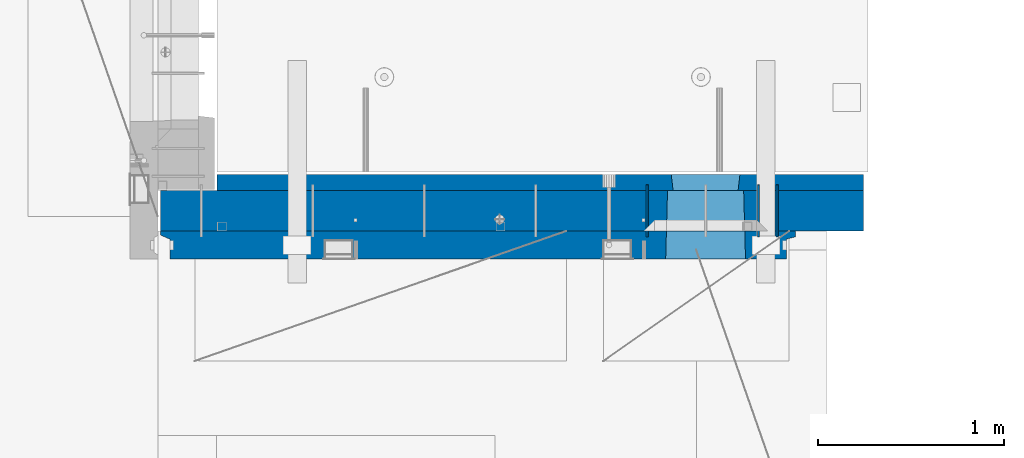
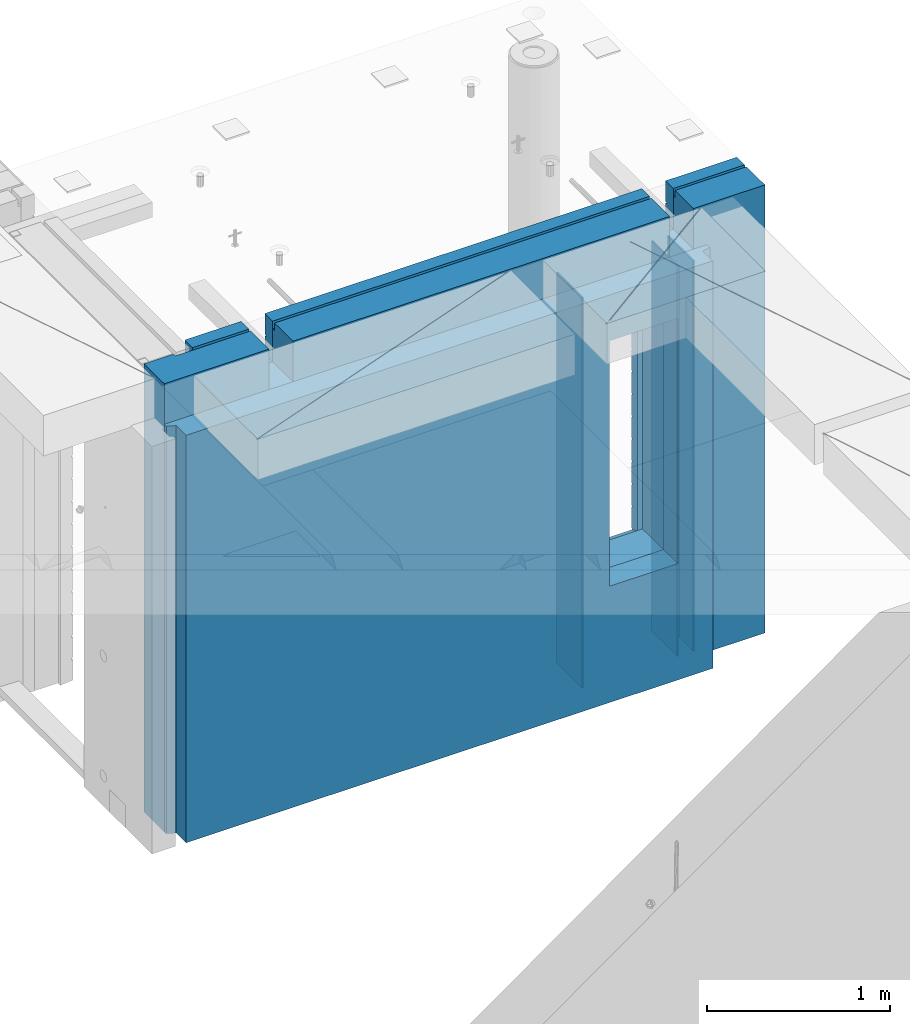
# One storey, part 207 of 309: 6 walls, 1 element without a shape of its own.
"""IFC2X3 building model written with IfcOpenShell, lengths in millimetres."""

from ifc_helpers import new_model, si_unit, frame, origin_with_axes, place, context, subcontext, project, spatial, faceted_brep, material, type_object, element, aggregate, save


model = new_model("IFC2X3")

# Units and contexts
model_context = context("Model", 3, precision=1e-05, world=origin_with_axes())
body_context = subcontext(model_context, "Body", "Model", "MODEL_VIEW")
ifc_project = project(units=[si_unit("LENGTHUNIT", "METRE", prefix="MILLI"), si_unit("AREAUNIT", "SQUARE_METRE"), si_unit("VOLUMEUNIT", "CUBIC_METRE"), si_unit("MASSUNIT", "GRAM", prefix="KILO"), si_unit("TIMEUNIT", "SECOND"), si_unit("PLANEANGLEUNIT", "RADIAN"), si_unit("SOLIDANGLEUNIT", "STERADIAN"), si_unit("THERMODYNAMICTEMPERATUREUNIT", "DEGREE_CELSIUS"), si_unit("LUMINOUSINTENSITYUNIT", "LUMEN")], contexts=[model_context])

# Site, building, storey
site_placement = place(None, origin_with_axes())
site = spatial("IfcSite", under=ifc_project, at=site_placement, CompositionType="ELEMENT")
building_placement = place(site_placement, origin_with_axes())
building = spatial("IfcBuilding", under=site, at=building_placement, CompositionType="ELEMENT")
storey_placement = place(building_placement, origin_with_axes())
storey = spatial("IfcBuildingStorey", under=building, at=storey_placement, Name="7", CompositionType="ELEMENT", Elevation=0.0)

# Assembly, walls
assembly_placement = place(storey_placement, origin_with_axes())
assembly = element("IfcElementAssembly", 1, at=assembly_placement, inside=storey, AssemblyPlace="NOTDEFINED", PredefinedType="REINFORCEMENT_UNIT")
ifc_material_1 = material(Name="Undefined")
wall_type_1 = type_object("IfcWallType", PredefinedType="NOTDEFINED")
wall_1_placement = place(assembly_placement, frame((34695.0, 20549.9951872276, 101115.0), z_axis=(0.0, 0.0, 1.0), x_axis=(0.0, 1.0, 0.0)))
wall_1 = element("IfcWall", 2, at=wall_1_placement, type_object=wall_type_1, material=ifc_material_1, Name="(PD)", context=body_context, shape_type="Brep", body=[
    faceted_brep([(0.0, 5.0, -1300.0), (0.0, 5.0, 1300.0), (280.0, 5.0, 1300.0), (280.0, 5.0, -1300.0), (0.0, -5.0, 1300.0), (280.0, -5.0, 1300.0), (0.0, -5.0, -1300.0), (280.0, -5.0, -1300.0)], [[[0, 1, 2, 3]], [[1, 4, 5, 2]], [[4, 6, 7, 5]], [[6, 0, 3, 7]], [[5, 7, 3, 2]], [[6, 4, 1, 0]]]),
])
wall_2_placement = place(assembly_placement, frame((34795.0, 20549.9951872276, 101115.0), z_axis=(0.0, 0.0, 1.0), x_axis=(0.0, 1.0, 0.0)))
wall_2 = element("IfcWall", 3, at=wall_2_placement, type_object=wall_type_1, material=ifc_material_1, Name="(PD)", context=body_context, shape_type="Brep", body=[
    faceted_brep([(0.0, 5.0, -1300.0), (0.0, 5.0, 1300.0), (280.0, 5.0, 1300.0), (280.0, 5.0, -1300.0), (0.0, -5.0, 1300.0), (280.0, -5.0, 1300.0), (0.0, -5.0, -1300.0), (280.0, -5.0, -1300.0)], [[[0, 1, 2, 3]], [[1, 4, 5, 2]], [[4, 6, 7, 5]], [[6, 0, 3, 7]], [[5, 7, 3, 2]], [[6, 4, 1, 0]]]),
])
wall_3_placement = place(assembly_placement, frame((34095.0, 20549.9951872276, 101115.0), z_axis=(0.0, 0.0, 1.0), x_axis=(0.0, 1.0, 0.0)))
wall_3 = element("IfcWall", 4, at=wall_3_placement, type_object=wall_type_1, material=ifc_material_1, Name="(PD)", context=body_context, shape_type="Brep", body=[
    faceted_brep([(0.0, 5.0, -1300.0), (0.0, 5.0, 1300.0), (280.0, 5.0, 1300.0), (280.0, 5.0, -1300.0), (0.0, -5.0, 1300.0), (280.0, -5.0, 1300.0), (0.0, -5.0, -1300.0), (280.0, -5.0, -1300.0)], [[[0, 1, 2, 3]], [[1, 4, 5, 2]], [[4, 6, 7, 5]], [[6, 0, 3, 7]], [[5, 7, 3, 2]], [[6, 4, 1, 0]]]),
])
ifc_material_2 = material(Name="COS5gt")
wall_type_2 = type_object("IfcWallType", PredefinedType="NOTDEFINED")
wall_4_placement = place(assembly_placement, frame((31475.0, 20689.9951872276, 101247.5), z_axis=(0.0, 0.0, 1.0), x_axis=(1.0, 0.0, 0.0)))
wall_4 = element("IfcWall", 5, at=wall_4_placement, type_object=wall_type_2, material=ifc_material_2, context=body_context, shape_type="Brep", body=[
    faceted_brep([(810.0, 110.0, 1442.5), (810.0, 90.0, 1442.5), (3185.0, 90.0, 1442.5), (3185.0, 110.0, 1442.5), (810.0, 90.0, 1492.5), (810.0, -110.0, 1492.5), (3185.0, -110.0, 1492.5), (3185.0, 90.0, 1492.5), (184.0, 90.0, 1442.5), (184.0, 90.0, 1492.5), (660.0, 90.0, 1492.5), (660.0, 90.0, 1442.5), (184.0, 110.0, 1492.5), (184.0, 110.0, 1442.5), (0.0, 110.0, 1492.5), (0.0, -110.0, 1492.5), (660.0, -110.0, 1492.5), (0.0, -110.0, -1492.5), (0.0, 110.0, -1492.5), (3785.0, 90.0, -1492.5), (184.0, 90.0, -1492.5), (184.0, 90.0, -1442.5), (3785.0, 90.0, -1442.5), (3785.0, -110.0, -1492.5), (184.0, 110.0, -1492.5), (184.0, 110.0, -1442.5), (3785.0, 110.0, -1442.5), (3785.0, 110.0, 1442.5), (3785.0, 90.0, 1442.5), (3785.0, 90.0, 1492.5), (3785.0, -110.0, 1492.5), (3335.0, 90.0, 1492.5), (3335.0, -110.0, 1492.5), (3185.0, -110.000000000004, 1222.5), (810.0, -110.0, 1222.5), (660.0, -110.0, 1222.5), (3335.0, -110.000000000004, 1222.5), (2724.05956312561, -110.000000000004, -713.445945945947), (2724.05956312561, -110.000000000007, 913.445945945947), (3145.94145501751, -110.000000000007, 913.445945945947), (3145.94145501751, -110.000000000004, -713.445945945947), (2730.00550907156, 110.0, -702.5), (2730.00550907156, 110.0, 907.5), (2730.00550907156, 110.0, -707.5), (3139.99550907157, 110.0, -707.5), (3109.99550907157, 110.0, -707.5), (2760.00550907156, 110.0, -707.5), (3139.99550907157, 110.0, 907.5), (3139.99550907157, 110.0, -702.5), (660.0, 110.0, 1442.5), (660.0, 109.999999999996, 1222.5), (810.0, 109.999999999996, 1222.5), (3185.0, 109.999999999996, 1222.5), (3335.0, 109.999999999996, 1222.5), (3335.0, 110.0, 1442.5), (3335.0, 90.0, 1442.5)], [[[0, 1, 2, 3]], [[4, 5, 6, 7]], [[8, 9, 10, 11]], [[12, 9, 8, 13]], [[9, 12, 14, 15, 16, 10]], [[17, 15, 14, 18]], [[19, 20, 21, 22]], [[23, 17, 18, 24, 20, 19]], [[25, 21, 20, 24]], [[26, 22, 21, 25]], [[27, 28, 29, 30, 23, 19, 22, 26]], [[30, 29, 31, 32]], [[33, 6, 5, 34, 35, 16, 15, 17, 23, 30, 32, 36], [37, 38, 39, 40]], [[41, 42, 38, 37, 43]], [[40, 44, 45, 46, 43, 37]], [[39, 47, 48, 44, 40]], [[38, 42, 47, 39]], [[27, 26, 25, 24, 18, 14, 12, 13, 49, 50, 51, 0, 3, 52, 53, 54], [41, 43, 46, 45, 44, 48, 47, 42]], [[28, 27, 54, 55]], [[29, 28, 55, 31]], [[54, 53, 36, 32, 31, 55]], [[52, 33, 36, 53]], [[3, 2, 7, 6, 33, 52]], [[1, 4, 7, 2]], [[0, 51, 34, 5, 4, 1]], [[50, 35, 34, 51]], [[49, 11, 10, 16, 35, 50]], [[13, 8, 11, 49]]]),
])
ifc_material_3 = material(Name="CONCRETE/C30/37")
wall_type_3 = type_object("IfcWallType", PredefinedType="NOTDEFINED")
wall_5_placement = place(assembly_placement, frame((31780.0, 20842.4951872276, 101247.5), z_axis=(0.0, 0.0, 1.0), x_axis=(1.0, 0.0, 0.0)))
wall_5 = element("IfcWall", 6, at=wall_5_placement, type_object=wall_type_3, material=ifc_material_3, context=body_context, shape_type="Brep", body=[
    faceted_brep([(3480.0, -42.5, 1492.5), (3480.0, 42.5, 1492.5), (3030.0, 42.5, 1492.5), (3030.0, -42.5, 1492.5), (3480.0, 42.4999992431694, 1356.99999988925), (3030.0, 42.4999993410347, 1356.99999988925), (3480.0, 32.4999991127006, 1355.00000040044), (3480.0, 32.4999992507037, 1344.99999999926), (3030.0, 32.4999992507037, 1344.99999999926), (3030.0, 32.4999991127006, 1355.00000040044), (3480.0, 42.4999996036895, 1342.99999994476), (3030.0, 42.4999996549377, 1342.99999994476), (3480.0, 42.4999993831152, 892.999999944761), (0.0, 42.5, 892.999999944761), (0.0, 32.4999992507037, 894.999999999258), (3480.0, 32.4999992507037, 894.999999999258), (0.0, 32.4999991127006, 905.00000040044), (3480.0, 32.4999991127006, 905.00000040044), (3480.0, 42.4999992431694, 906.999999889245), (0.0, 42.5, 906.999999889245), (0.0, 42.5, 1042.99999994476), (3480.0, 42.4999994189675, 1042.99999994476), (0.0, 32.4999992507037, 1044.99999999926), (3480.0, 32.4999992507037, 1044.99999999926), (0.0, 32.4999991127006, 1055.00000040044), (3480.0, 32.4999991127006, 1055.00000040044), (3480.0, 42.4999992431694, 1056.99999988925), (0.0, 42.5, 1056.99999988925), (0.0, 42.5, 1192.99999994476), (3480.0, 42.4999994795144, 1192.99999994476), (0.0, 32.4999992507037, 1194.99999999926), (3480.0, 32.4999992507037, 1194.99999999926), (0.0, 32.4999991127006, 1205.00000040044), (3480.0, 32.4999991127006, 1205.00000040044), (3480.0, 42.4999992431694, 1206.99999988925), (0.0, 42.5, 1206.99999988925), (-3.63797880709171e-12, 32.4999992507037, 1344.99999999926), (-3.63797880709171e-12, 32.4999991127006, 1355.00000040044), (355.0, 32.4999991127006, 1355.00000040044), (355.0, 32.4999992507037, 1344.99999999926), (0.0, 42.5, 1342.99999994476), (355.0, 42.4999999595711, 1342.99999994476), (505.0, 32.4999992507037, 1344.99999999926), (505.0, 32.4999991127006, 1355.00000040044), (2880.0, 32.4999991127006, 1355.00000040044), (2880.0, 32.4999992507037, 1344.99999999926), (505.0, 42.4999999424908, 1342.99999994476), (2880.0, 42.4999996720217, 1342.99999994476), (355.0, 42.4999998715975, 1222.5), (505.0, 42.4999998467429, 1222.5), (2880.0, 42.4999994331811, 1222.5), (3030.0, 42.4999994081736, 1222.5), (355.0, -42.5, 1222.5), (505.0, -42.5, 1222.5), (505.0, 42.5, 1492.5), (505.0, 42.4999998901731, 1356.99999988925), (505.0, -42.5, 1492.5), (2880.0, -42.5, 1492.5), (2880.0, 42.5, 1492.5), (2880.0, 42.4999993736565, 1356.99999988925), (2880.0, -42.5000000000036, 1222.5), (3030.0, -42.5000000000036, 1222.5), (3480.0, -42.5, -1492.5), (3480.0, 42.5, -1492.5), (3480.0, 42.5, -1357.00000005524), (3480.0, 32.4999992507037, -1355.00000000074), (3480.0, 32.4999991127006, -1344.99999959956), (3480.0, 42.4999992431694, -1343.00000011075), (3480.0, 42.4999992794692, -1207.00000005524), (3480.0, 32.4999992507037, -1205.00000000074), (3480.0, 32.4999991127006, -1194.99999959956), (3480.0, 42.4999992431694, -1193.00000011075), (3480.0, 42.4999992814955, -1057.00000005524), (3480.0, 32.4999992507037, -1055.00000000074), (3480.0, 32.4999991127006, -1044.99999959956), (3480.0, 42.4999992431694, -1043.00000011075), (3480.0, 42.4999992837656, -907.000000055239), (3480.0, 32.4999992507037, -905.000000000742), (3480.0, 32.4999991127006, -894.99999959956), (3480.0, 42.4999992431694, -893.000000110755), (3480.0, 42.4999992863159, -757.000000055239), (3480.0, 32.4999992507037, -755.000000000742), (3480.0, 32.4999991127006, -744.99999959956), (3480.0, 42.4999992431694, -743.000000110755), (3480.0, 42.4999992892117, -607.000000055239), (3480.0, 32.4999992507037, -605.000000000742), (3480.0, 32.4999991127006, -594.99999959956), (3480.0, 42.4999992431694, -593.000000110755), (3480.0, 42.4999992925223, -457.000000055239), (3480.0, 32.4999992507037, -455.000000000742), (3480.0, 32.4999991127006, -444.99999959956), (3480.0, 42.4999992431694, -443.000000110755), (3480.0, 42.4999992963494, -307.000000055239), (3480.0, 32.4999992507037, -305.000000000742), (3480.0, 32.4999991127006, -294.99999959956), (3480.0, 42.4999992431694, -293.000000110755), (3480.0, 42.4999993008169, -157.000000055239), (3480.0, 32.4999992507037, -155.000000000742), (3480.0, 32.4999991127006, -144.99999959956), (3480.0, 42.4999992431694, -143.000000110755), (3480.0, 42.4999993061028, -7.00000005523907), (3480.0, 32.4999992507037, -5.00000000074215), (3480.0, 32.4999991127006, 5.0000004004396), (3480.0, 42.4999992431694, 6.99999988924537), (3480.0, 42.4999993124584, 142.999999944761), (3480.0, 32.4999992507037, 144.999999999258), (3480.0, 32.4999991127006, 155.00000040044), (3480.0, 42.4999992431694, 156.999999889245), (3480.0, 42.49999932024, 292.999999944761), (3480.0, 32.4999992507037, 294.999999999258), (3480.0, 32.4999991127006, 305.00000040044), (3480.0, 42.4999992431694, 306.999999889245), (3480.0, 42.4999993299934, 442.999999944761), (3480.0, 32.4999992507037, 444.999999999258), (3480.0, 32.4999991127006, 455.00000040044), (3480.0, 42.4999992431694, 456.999999889245), (3480.0, 42.4999993425699, 592.999999944761), (3480.0, 32.4999992507037, 594.999999999258), (3480.0, 32.4999991127006, 605.00000040044), (3480.0, 42.4999992431694, 606.999999889245), (3480.0, 42.4999993594065, 742.999999944761), (3480.0, 32.4999992507037, 744.999999999258), (3480.0, 32.4999991127006, 755.00000040044), (3480.0, 42.4999992431694, 756.999999889245), (0.0, -42.5, -1492.5), (0.0, 42.5, -1492.5), (0.0, 42.5, -1357.00000005524), (0.0, 32.4999992507037, -1355.00000000074), (0.0, 32.4999991127006, -1344.99999959956), (0.0, 42.5, -1343.00000011075), (0.0, 42.5, -1207.00000005524), (0.0, 32.4999992507037, -1205.00000000074), (0.0, 32.4999991127006, -1194.99999959956), (0.0, 42.5, -1193.00000011075), (0.0, 42.5, -1057.00000005524), (0.0, 32.4999992507037, -1055.00000000074), (0.0, 32.4999991127006, -1044.99999959956), (0.0, 42.5, -1043.00000011075), (0.0, 42.5, -907.000000055239), (0.0, 32.4999992507037, -905.000000000742), (0.0, 32.4999991127006, -894.99999959956), (0.0, 42.5, -893.000000110755), (0.0, 42.5, -757.000000055239), (2445.00550907156, 42.4999994985737, -757.000000055239), (2445.00550907156, 42.5, -757.5), (2814.99550907157, 42.5, -757.5), (2814.99550907157, 42.5, -757.000000055239), (2445.1570241794, 41.2121215834159, -756.742424460826), (2814.84399396603, 41.2121216029336, -756.742424472308), (0.0, 32.4999992507037, -755.000000000742), (0.0, 32.4999991127006, 755.00000040044), (0.0, 42.5, 756.999999889245), (2445.00550907156, 42.4999994682585, 756.999999889245), (2446.18197976419, 32.4999991127006, 755.00000040044), (0.0, 32.4999992507037, 744.999999999258), (2446.18197974795, 32.4999992507037, 744.999999999258), (0.0, 42.5, 742.999999944761), (2445.00550907156, 42.4999995499275, 742.999999944761), (0.0, 42.5, 606.999999889245), (2445.00550907156, 42.4999994682585, 606.999999889245), (3.63797880709171e-12, 32.4999991127006, 605.00000040044), (2446.18197976419, 32.4999991127006, 605.00000040044), (3.63797880709171e-12, 32.4999992507037, 594.999999999258), (2446.18197974795, 32.4999992507037, 594.999999999258), (0.0, 42.5, 592.999999944761), (2445.00550907156, 42.4999995380967, 592.999999944761), (0.0, 42.5, 456.999999889245), (2445.00550907156, 42.4999994682585, 456.999999889245), (0.0, 32.4999991127006, 455.00000040044), (2446.18197976419, 32.4999991127006, 455.00000040044), (0.0, 32.4999992507037, 444.999999999258), (2446.18197974795, 32.4999992507037, 444.999999999258), (0.0, 42.5, 442.999999944761), (2445.00550907156, 42.4999995292637, 442.999999944761), (0.0, 42.5, 306.999999889245), (2445.00550907156, 42.4999994682585, 306.999999889245), (-3.63797880709171e-12, 32.4999991127006, 305.00000040044), (2446.18197976419, 32.4999991127006, 305.00000040044), (-3.63797880709171e-12, 32.4999992507037, 294.999999999258), (2446.18197974795, 32.4999992507037, 294.999999999258), (0.0, 42.5, 292.999999944761), (2445.00550907156, 42.4999995224098, 292.999999944761), (0.0, 42.5, 156.999999889245), (2445.00550907156, 42.4999994682585, 156.999999889245), (-3.63797880709171e-12, 32.4999991127006, 155.00000040044), (2446.18197976419, 32.4999991127006, 155.00000040044), (-3.63797880709171e-12, 32.4999992507037, 144.999999999258), (2446.18197974795, 32.4999992507037, 144.999999999258), (0.0, 42.5, 142.999999944761), (2445.00550907156, 42.4999995169419, 142.999999944761), (0.0, 42.5, 6.99999988924537), (2445.00550907156, 42.4999994682585, 6.99999988924537), (0.0, 32.4999991127006, 5.0000004004396), (2446.18197976419, 32.4999991127006, 5.0000004004396), (0.0, 32.4999992507037, -5.00000000074215), (2446.18197974795, 32.4999992507037, -5.00000000074215), (0.0, 42.5, -7.00000005523907), (2445.00550907156, 42.4999995124781, -7.00000005523907), (0.0, 42.5, -143.000000110755), (2445.00550907156, 42.4999994682585, -143.000000110755), (3.63797880709171e-12, 32.4999991127006, -144.99999959956), (2446.18197976419, 32.4999991127006, -144.99999959956), (3.63797880709171e-12, 32.4999992507037, -155.000000000742), (2446.18197974795, 32.4999992507037, -155.000000000742), (0.0, 42.5, -157.000000055239), (2445.00550907156, 42.4999995087601, -157.000000055239), (0.0, 42.5, -293.000000110755), (2445.00550907156, 42.4999994682585, -293.000000110755), (0.0, 32.4999991127006, -294.99999959956), (2446.18197976419, 32.4999991127006, -294.99999959956), (0.0, 32.4999992507037, -305.000000000742), (2446.18197974795, 32.4999992507037, -305.000000000742), (0.0, 42.5, -307.000000055239), (2445.00550907156, 42.4999995056241, -307.000000055239), (0.0, 42.5, -443.000000110755), (2445.00550907156, 42.4999994682585, -443.000000110755), (0.0, 32.4999991127006, -444.99999959956), (2446.18197976419, 32.4999991127006, -444.99999959956), (0.0, 32.4999992507037, -455.000000000742), (2446.18197974795, 32.4999992507037, -455.000000000742), (0.0, 42.5, -457.000000055239), (2445.00550907156, 42.4999995029357, -457.000000055239), (0.0, 42.5, -593.000000110755), (2445.00550907156, 42.4999994682585, -593.000000110755), (3.63797880709171e-12, 32.4999991127006, -594.99999959956), (2446.18197976419, 32.4999991127006, -594.99999959956), (3.63797880709171e-12, 32.4999992507037, -605.000000000742), (2446.18197974795, 32.4999992507037, -605.000000000742), (0.0, 42.5, -607.000000055239), (2445.00550907156, 42.499999500611, -607.000000055239), (0.0, 42.5, -743.000000110755), (2445.00550907156, 42.4999994682585, -743.000000110755), (0.0, 32.4999991127006, -744.99999959956), (2446.18197976419, 32.4999991127006, -744.99999959956), (2446.18197975344, 32.4999992040284, -751.617646590603), (2455.00550907156, -42.5, -707.5), (2804.99550907157, -42.5, -707.5), (2813.81903838969, 32.4999992040284, -751.617646590603), (2813.81903837895, 32.4999991127006, -744.99999959956), (2814.99550907157, 42.4999993877937, -743.000000110755), (2814.99550907157, 42.4999994250393, -607.000000055239), (2813.81903839519, 32.4999992507037, -605.000000000742), (2813.81903837895, 32.4999991127006, -594.99999959956), (2814.99550907157, 42.4999993877937, -593.000000110755), (2814.99550907157, 42.4999994277168, -457.000000055239), (2813.81903839519, 32.4999992507037, -455.000000000742), (2813.81903837895, 32.4999991127006, -444.99999959956), (2814.99550907157, 42.4999993877937, -443.000000110755), (2814.99550907157, 42.4999994308128, -307.000000055239), (2813.81903839519, 32.4999992507037, -305.000000000742), (2813.81903837895, 32.4999991127006, -294.99999959956), (2814.99550907157, 42.4999993877937, -293.000000110755), (2814.99550907157, 42.4999994344253, -157.000000055239), (2813.81903839519, 32.4999992507037, -155.000000000742), (2813.81903837895, 32.4999991127006, -144.99999959956), (2814.99550907157, 42.4999993877937, -143.000000110755), (2814.99550907157, 42.4999994387035, -7.00000005523907), (2813.81903839519, 32.4999992507037, -5.00000000074215), (2813.81903837895, 32.4999991127006, 5.0000004004396), (2814.99550907157, 42.4999993877937, 6.99999988924537), (2814.99550907157, 42.499999443844, 142.999999944761), (2813.81903839519, 32.4999992507037, 144.999999999258), (2813.81903837895, 32.4999991127006, 155.00000040044), (2814.99550907157, 42.4999993877937, 156.999999889245), (2814.99550907157, 42.4999994501377, 292.999999944761), (2813.81903839519, 32.4999992507037, 294.999999999258), (2813.81903837895, 32.4999991127006, 305.00000040044), (2814.99550907157, 42.4999993877937, 306.999999889245), (2814.99550907157, 42.4999994580285, 442.999999944761), (2813.81903839519, 32.4999992507037, 444.999999999258), (2813.81903837895, 32.4999991127006, 455.00000040044), (2814.99550907157, 42.4999993877937, 456.999999889245), (2814.99550907157, 42.4999994682003, 592.999999944761), (2813.81903839519, 32.4999992507037, 594.999999999258), (2813.81903837895, 32.4999991127006, 605.00000040044), (2814.99550907157, 42.4999993877937, 606.999999889245), (2814.99550907157, 42.4999994818209, 742.999999944761), (2813.81903839519, 32.4999992507037, 744.999999999258), (2813.81903837895, 32.4999991127006, 755.00000040044), (2814.99550907157, 42.4999993877937, 756.999999889245), (2455.00550907156, 42.5, 882.5), (2445.00550907156, 42.5, 882.5), (2814.99550907157, 42.5, 882.5), (2804.99550907157, 42.5, 882.5), (2455.00550907156, -42.5, 882.5), (2455.00550907156, -42.5, 887.5), (2804.99550907157, -42.5, 887.5), (2804.99550907157, -42.5, 882.5), (355.0, -42.5, 1492.5), (0.0, -42.5, 1492.5), (0.0, 42.5, 1492.5), (355.0, 42.5, 1492.5), (0.0, 42.5, 1356.99999988925), (355.0, 42.4999999227948, 1356.99999988925)], [[[0, 1, 2, 3]], [[1, 4, 5, 2]], [[6, 7, 8, 9]], [[7, 10, 11, 8]], [[12, 13, 14, 15]], [[15, 14, 16, 17]], [[18, 17, 16, 19]], [[18, 19, 20, 21]], [[21, 20, 22, 23]], [[23, 22, 24, 25]], [[26, 25, 24, 27]], [[26, 27, 28, 29]], [[29, 28, 30, 31]], [[31, 30, 32, 33]], [[34, 33, 32, 35]], [[36, 37, 38, 39]], [[40, 36, 39, 41]], [[42, 43, 44, 45]], [[46, 42, 45, 47]], [[10, 34, 35, 40, 41, 48, 49, 46, 47, 50, 51, 11]], [[48, 52, 53, 49]], [[54, 55, 43, 42, 46, 49, 53, 56]], [[54, 56, 57, 58]], [[55, 54, 58, 59]], [[43, 55, 59, 44]], [[58, 57, 60, 50, 47, 45, 44, 59]], [[50, 60, 61, 51]], [[2, 5, 9, 8, 11, 51, 61, 3]], [[4, 6, 9, 5]], [[1, 0, 62, 63, 64, 65, 66, 67, 68, 69, 70, 71, 72, 73, 74, 75, 76, 77, 78, 79, 80, 81, 82, 83, 84, 85, 86, 87, 88, 89, 90, 91, 92, 93, 94, 95, 96, 97, 98, 99, 100, 101, 102, 103, 104, 105, 106, 107, 108, 109, 110, 111, 112, 113, 114, 115, 116, 117, 118, 119, 120, 121, 122, 123, 12, 15, 17, 18, 21, 23, 25, 26, 29, 31, 33, 34, 10, 7, 6, 4]], [[124, 125, 63, 62]], [[63, 125, 126, 64]], [[64, 126, 127, 65]], [[65, 127, 128, 66]], [[67, 66, 128, 129]], [[67, 129, 130, 68]], [[68, 130, 131, 69]], [[69, 131, 132, 70]], [[71, 70, 132, 133]], [[71, 133, 134, 72]], [[72, 134, 135, 73]], [[73, 135, 136, 74]], [[75, 74, 136, 137]], [[75, 137, 138, 76]], [[76, 138, 139, 77]], [[77, 139, 140, 78]], [[79, 78, 140, 141]], [[80, 79, 141, 142, 143, 144, 145, 146]], [[143, 147, 144]], [[144, 147, 148, 145]], [[146, 145, 148]], [[147, 143, 142, 149, 81, 80, 146, 148]], [[150, 151, 152, 153]], [[154, 150, 153, 155]], [[156, 154, 155, 157]], [[158, 156, 157, 159]], [[160, 158, 159, 161]], [[162, 160, 161, 163]], [[164, 162, 163, 165]], [[166, 164, 165, 167]], [[168, 166, 167, 169]], [[170, 168, 169, 171]], [[172, 170, 171, 173]], [[174, 172, 173, 175]], [[176, 174, 175, 177]], [[178, 176, 177, 179]], [[180, 178, 179, 181]], [[182, 180, 181, 183]], [[184, 182, 183, 185]], [[186, 184, 185, 187]], [[188, 186, 187, 189]], [[190, 188, 189, 191]], [[192, 190, 191, 193]], [[194, 192, 193, 195]], [[196, 194, 195, 197]], [[198, 196, 197, 199]], [[200, 198, 199, 201]], [[202, 200, 201, 203]], [[204, 202, 203, 205]], [[206, 204, 205, 207]], [[208, 206, 207, 209]], [[210, 208, 209, 211]], [[212, 210, 211, 213]], [[214, 212, 213, 215]], [[216, 214, 215, 217]], [[218, 216, 217, 219]], [[220, 218, 219, 221]], [[222, 220, 221, 223]], [[224, 222, 223, 225]], [[226, 224, 225, 227]], [[228, 226, 227, 229]], [[230, 228, 229, 231]], [[232, 230, 231, 233]], [[234, 235, 236, 237]], [[82, 81, 149, 232, 233, 234, 237, 238]], [[83, 82, 238, 239]], [[84, 83, 239, 240]], [[85, 84, 240, 241]], [[86, 85, 241, 242]], [[87, 86, 242, 243]], [[88, 87, 243, 244]], [[89, 88, 244, 245]], [[90, 89, 245, 246]], [[91, 90, 246, 247]], [[92, 91, 247, 248]], [[93, 92, 248, 249]], [[94, 93, 249, 250]], [[95, 94, 250, 251]], [[96, 95, 251, 252]], [[97, 96, 252, 253]], [[98, 97, 253, 254]], [[99, 98, 254, 255]], [[100, 99, 255, 256]], [[101, 100, 256, 257]], [[102, 101, 257, 258]], [[103, 102, 258, 259]], [[104, 103, 259, 260]], [[105, 104, 260, 261]], [[106, 105, 261, 262]], [[107, 106, 262, 263]], [[108, 107, 263, 264]], [[109, 108, 264, 265]], [[110, 109, 265, 266]], [[111, 110, 266, 267]], [[112, 111, 267, 268]], [[113, 112, 268, 269]], [[114, 113, 269, 270]], [[115, 114, 270, 271]], [[116, 115, 271, 272]], [[117, 116, 272, 273]], [[118, 117, 273, 274]], [[119, 118, 274, 275]], [[120, 119, 275, 276]], [[121, 120, 276, 277]], [[122, 121, 277, 278]], [[123, 122, 278, 279]], [[280, 281, 152, 151, 13, 12, 123, 279, 282, 283]], [[284, 235, 234, 233, 231, 229, 227, 225, 223, 221, 219, 217, 215, 213, 211, 209, 207, 205, 203, 201, 199, 197, 195, 193, 191, 189, 187, 185, 183, 181, 179, 177, 175, 173, 171, 169, 167, 165, 163, 161, 159, 157, 155, 153, 152, 281, 285]], [[280, 283, 282, 286, 285, 281]], [[279, 278, 277, 276, 275, 274, 273, 272, 271, 270, 269, 268, 267, 266, 265, 264, 263, 262, 261, 260, 259, 258, 257, 256, 255, 254, 253, 252, 251, 250, 249, 248, 247, 246, 245, 244, 243, 242, 241, 240, 239, 238, 237, 236, 287, 286, 282]], [[60, 57, 56, 53, 52, 288, 289, 124, 62, 0, 3, 61], [236, 235, 284, 285, 286, 287]], [[290, 289, 288, 291]], [[36, 40, 35, 32, 30, 28, 27, 24, 22, 20, 19, 16, 14, 13, 151, 150, 154, 156, 158, 160, 162, 164, 166, 168, 170, 172, 174, 176, 178, 180, 182, 184, 186, 188, 190, 192, 194, 196, 198, 200, 202, 204, 206, 208, 210, 212, 214, 216, 218, 220, 222, 224, 226, 228, 230, 232, 149, 142, 141, 140, 139, 138, 137, 136, 135, 134, 133, 132, 131, 130, 129, 128, 127, 126, 125, 124, 289, 290, 292, 37]], [[37, 292, 293, 38]], [[291, 288, 52, 48, 41, 39, 38, 293]], [[292, 290, 291, 293]]]),
])
ifc_material_4 = material(Name="CONCRETE/C25/30")
wall_type_4 = type_object("IfcWallType", PredefinedType="NOTDEFINED")
wall_6_placement = place(assembly_placement, frame((31475.0, 20504.9951872276, 101112.5), z_axis=(0.0, 0.0, 1.0), x_axis=(1.0, 0.0, 0.0)))
wall_6 = element("IfcWall", 7, at=wall_6_placement, type_object=wall_type_4, material=ifc_material_4, context=body_context, shape_type="Brep", body=[
    faceted_brep([(3370.0, -75.0, 1357.5), (3370.0, -75.0, -1357.5), (3370.0, 32.0, -1357.5), (3370.0, 32.0, 1357.5), (3420.0, 75.0, 1357.5), (0.0, 75.0, 1357.5), (0.0, 53.6645811319431, 1357.5), (49.9951872275633, 32.0, 1357.5), (49.9951872275633, -75.0, 1357.5), (3420.0, 45.0, 1357.5), (49.9951872275633, 32.0, -1357.5), (49.9951872275633, -75.0, -1357.5), (0.0, 53.6645811319431, -1357.5), (0.0, 75.0, -1357.5), (3420.0, 75.0, -1357.5), (3420.0, 45.0, -1357.5), (2720.00550907156, -75.0, 1052.5), (2724.05956312561, 75.0, 1048.44594594595), (3145.94145501751, 75.0, 1048.44594594595), (3149.99550907157, -75.0, 1052.5), (2724.05956312561, 75.0, -578.445945945947), (3145.94145501751, 75.0, -578.445945945947), (3149.99550907157, -75.0, -582.5), (2720.00550907156, -75.0, -582.5)], [[[0, 1, 2, 3]], [[4, 5, 6, 7, 8, 0, 3, 9]], [[7, 10, 11, 8]], [[6, 12, 10, 7]], [[5, 13, 12, 6]], [[1, 11, 10, 12, 13, 14, 15, 2]], [[9, 3, 2, 15]], [[14, 4, 9, 15]], [[16, 17, 18, 19]], [[13, 5, 4, 14], [20, 21, 18, 17]], [[19, 18, 21, 22]], [[8, 11, 1, 0], [23, 16, 19, 22]], [[17, 16, 23, 20]], [[22, 21, 20, 23]]]),
])
aggregate(assembly, [wall_1, wall_2, wall_3, wall_5, wall_4, wall_6])

save(model, "model.ifc")
